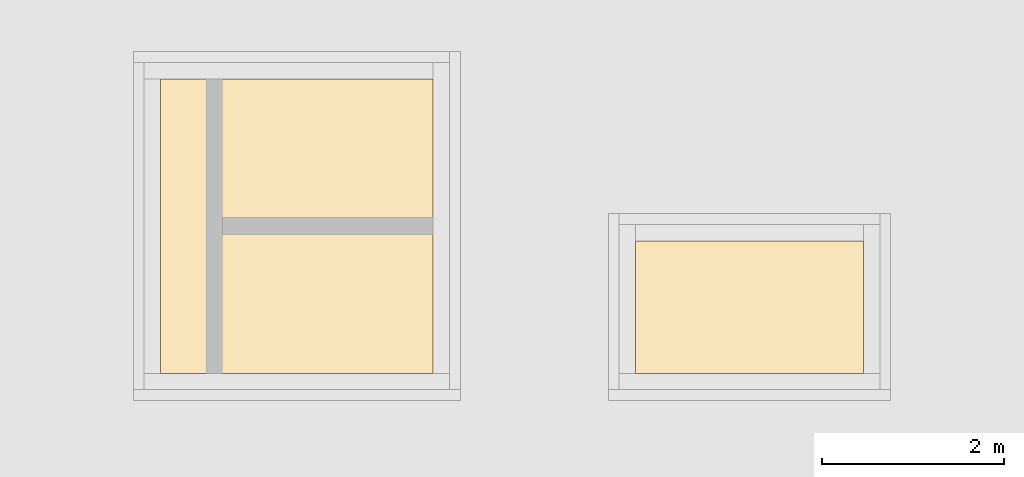
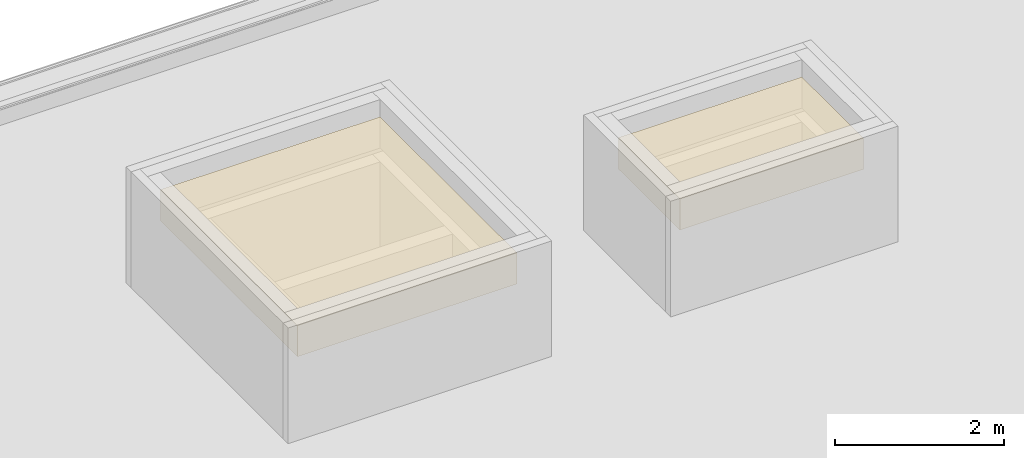
# One storey, part 3 of 3: 2 coverings.
"""IFC4 building model written with IfcOpenShell, lengths in metres."""

from ifc_helpers import new_model, entity, si_unit, converted_unit, derived_unit, direction, frame, origin_with_axes, place, context, subcontext, project, spatial, polygons, material, type_object, element, save


model = new_model("IFC4")

# Units and contexts
model_context = context("Model", 3, precision=1e-05, world=origin_with_axes(), true_north=direction((0.0, 1.0)))
body_context = subcontext(model_context, "Body", "Model", "MODEL_VIEW")
ifc_project = project(units=[si_unit("LENGTHUNIT", "METRE"), si_unit("AREAUNIT", "SQUARE_METRE"), si_unit("VOLUMEUNIT", "CUBIC_METRE"), converted_unit("PLANEANGLEUNIT", "DEGREE", entity("IfcPlaneAngleMeasure", 0.0174532925199433), si_unit("PLANEANGLEUNIT", "RADIAN"), dimensions=[0, 0, 0, 0, 0, 0, 0]), converted_unit("TIMEUNIT", "Year", entity("IfcTimeMeasure", 31557600.0), si_unit("TIMEUNIT", "SECOND"), dimensions=[0, 0, 1, 0, 0, 0, 0]), si_unit("MASSUNIT", "GRAM", prefix="KILO"), si_unit("THERMODYNAMICTEMPERATUREUNIT", "DEGREE_CELSIUS"), si_unit("LUMINOUSINTENSITYUNIT", "LUMEN"), si_unit("ENERGYUNIT", "JOULE", prefix="MEGA"), derived_unit("THERMALCONDUCTANCEUNIT", [(si_unit("POWERUNIT", "WATT"), 1), (si_unit("LENGTHUNIT", "METRE"), -1), (si_unit("THERMODYNAMICTEMPERATUREUNIT", "KELVIN"), -1)]), derived_unit("SPECIFICHEATCAPACITYUNIT", [(si_unit("ENERGYUNIT", "JOULE"), 1), (si_unit("MASSUNIT", "GRAM", prefix="KILO"), -1), (si_unit("THERMODYNAMICTEMPERATUREUNIT", "KELVIN"), -1)]), derived_unit("MASSDENSITYUNIT", [(si_unit("MASSUNIT", "GRAM", prefix="KILO"), 1), (si_unit("VOLUMEUNIT", "CUBIC_METRE"), -1)])], contexts=[model_context])

# Site, building, storey
site_placement = place(None, origin_with_axes())
site = spatial("IfcSite", under=ifc_project, at=site_placement, CompositionType="ELEMENT")
building_placement = place(site_placement, origin_with_axes())
building = spatial("IfcBuilding", under=site, at=building_placement, CompositionType="ELEMENT")
storey_placement = place(building_placement, frame((0.0, 0.0, 13.5), z_axis=(0.0, 0.0, 1.0), x_axis=(1.0, 0.0, 0.0)))
storey = spatial("IfcBuildingStorey", under=building, at=storey_placement, Name="Dach", CompositionType="ELEMENT", Elevation=13.5)

# Coverings
ifc_material = material()
covering_type = type_object("IfcCoveringType", Name="450", PredefinedType="ROOFING")
covering_1_placement = place(storey_placement, frame((28.45800000000001, 7.234999945467554, 2.149999999999999), z_axis=(0.0, 0.0, 1.0), x_axis=(1.0, 0.0, 0.0)))
element("IfcCovering", 1, at=covering_1_placement, inside=storey, type_object=covering_type, material=ifc_material, Name="Decke-001", PredefinedType="ROOFING", context=body_context, shape_type="Tessellation", body=[
    polygons([(0.0, 0.0, 0.0), (0.0, 0.0, -0.4499999999999993), (2.999999999999996, 0.0, -0.4499999999999993), (2.999999999999996, 0.0, 0.0), (0.0, 3.240000000000001, 0.0), (0.0, 3.240000000000001, -0.4499999999999993), (2.999999999999996, 3.240000000000001, -0.4499999999999993), (2.999999999999996, 3.240000000000001, 0.0)], [[[1, 2, 3, 4]], [[5, 6, 2, 1]], [[3, 2, 6, 7]], [[4, 3, 7, 8]], [[5, 1, 4, 8]], [[8, 7, 6, 5]]], closed=True),
])
covering_2_placement = place(storey_placement, frame((33.685, 7.234999945467555, 2.149999999999999), z_axis=(0.0, 0.0, 1.0), x_axis=(1.0, 0.0, 0.0)))
element("IfcCovering", 2, at=covering_2_placement, inside=storey, type_object=covering_type, material=ifc_material, Name="Decke-001", PredefinedType="ROOFING", context=body_context, shape_type="Tessellation", body=[
    polygons([(0.0, 0.0, 0.0), (0.0, 0.0, -0.4499999999999993), (2.508000000000003, 0.0, -0.4499999999999993), (2.508000000000003, 0.0, 0.0), (0.0, 1.458000000000009, 0.0), (0.0, 1.458000000000009, -0.4499999999999993), (2.508000000000003, 1.458000000000009, -0.4499999999999993), (2.508000000000003, 1.458000000000009, 0.0)], [[[1, 2, 3, 4]], [[5, 6, 2, 1]], [[3, 2, 6, 7]], [[4, 3, 7, 8]], [[5, 1, 4, 8]], [[8, 7, 6, 5]]], closed=True),
])

save(model, "model.ifc")
